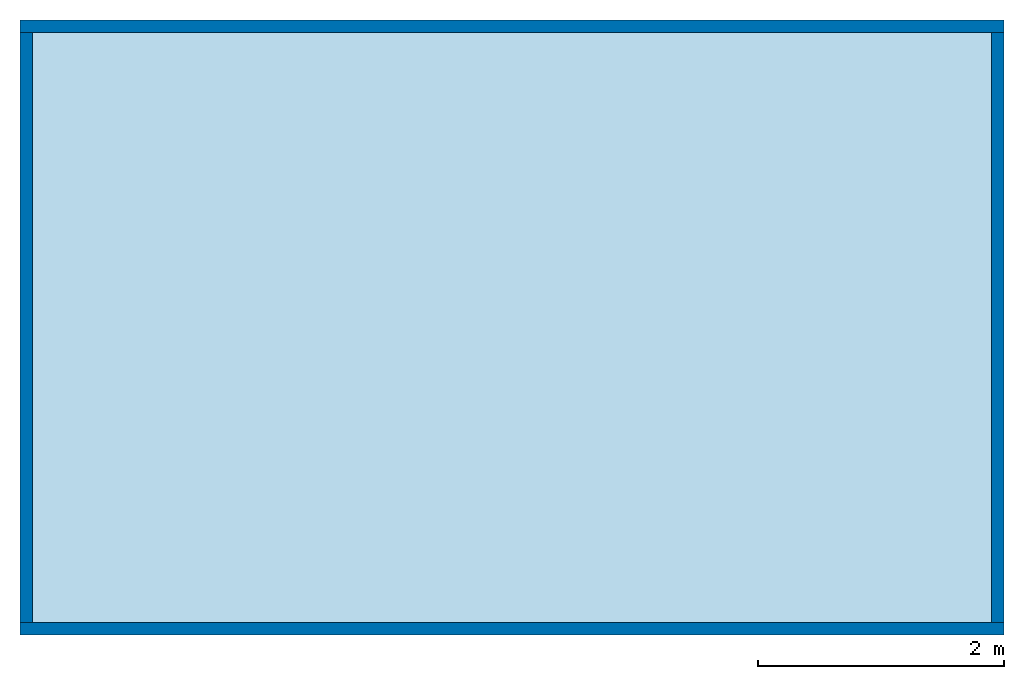
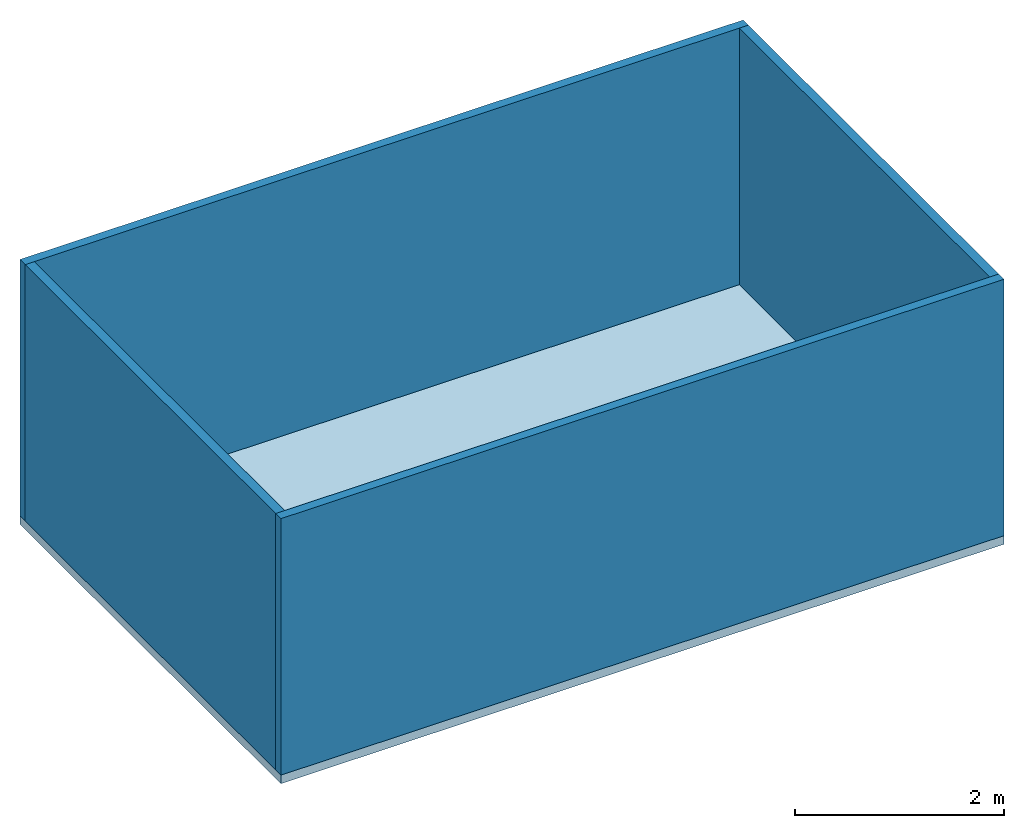
# One storey: 4 walls, 1 slab.
"""IFC4 building model written with IfcOpenShell, lengths in metres."""

from ifc_helpers import new_model, entity, si_unit, converted_unit, frame, origin_with_axes, origin_2d_with_axis, place, context, subcontext, project, spatial, line, indexed_curve, outline, extrude, material, layer, layer_set, layer_usage, type_object, element, save


model = new_model("IFC4")

# Units and contexts
model_context = context("Model", 3, precision=1e-05, world=origin_with_axes())
plan_context = context("Plan", 2, precision=1e-05, world=origin_2d_with_axis())
body_context = subcontext(model_context, "Body", "Model", "MODEL_VIEW")
ifc_project = project(units=[converted_unit("PLANEANGLEUNIT", "degree", entity("IfcReal", 0.0174532925199433), si_unit("PLANEANGLEUNIT", "RADIAN"), dimensions=[0, 0, 0, 0, 0, 0, 0]), si_unit("AREAUNIT", "SQUARE_METRE"), si_unit("VOLUMEUNIT", "CUBIC_METRE"), si_unit("LENGTHUNIT", "METRE")], contexts=[model_context, plan_context])

# Site, building, storey
site_placement = place(None, origin_with_axes())
site = spatial("IfcSite", under=ifc_project, at=site_placement)
building_placement = place(site_placement, origin_with_axes())
building = spatial("IfcBuilding", under=site, at=building_placement, Name="Building")
storey_placement = place(building_placement, origin_with_axes())
storey = spatial("IfcBuildingStorey", under=building, at=storey_placement, Name="Storey")

# Slab
ifc_material = material()
ifc_layer_1 = layer(ifc_material, 0.1)
ifc_layer_set_1 = layer_set([ifc_layer_1])
ifc_layer_usage_1 = layer_usage(ifc_layer_set_1, "AXIS3", "POSITIVE", 0.0)
slab_type = type_object("IfcSlabType", Name="slab", PredefinedType="FLOOR", material=ifc_layer_set_1)
slab_placement = place(storey_placement, frame((0.0, 0.0, -0.100000001490116), z_axis=(0.0, 0.0, 1.0), x_axis=(1.0, 0.0, 0.0)))
element("IfcSlab", 1, at=slab_placement, inside=storey, type_object=slab_type, material=ifc_layer_usage_1, Name="Slab", context=body_context, shape_type="SweptSolid", body=[
    extrude(outline(indexed_curve([(0.0, 0.0), (8.0, 0.0), (8.0, 5.0), (0.0, 5.0)], segments=[line(3, 2), line(2, 1), line(1, 4), line(4, 3)], self_intersect=False)), None, (0.0, 0.0, 1.0), 0.1),
])

# Walls
ifc_layer_2 = layer(ifc_material, 0.1)
ifc_layer_set_2 = layer_set([ifc_layer_2])
ifc_layer_usage_2 = layer_usage(ifc_layer_set_2, "AXIS2", "POSITIVE", 0.0)
wall_type = type_object("IfcWallType", Name="wall", PredefinedType="SOLIDWALL", material=ifc_layer_set_2)
wall_1_placement = place(storey_placement, origin_with_axes())
element("IfcWall", 2, at=wall_1_placement, inside=storey, type_object=wall_type, material=ifc_layer_usage_2, Name="Wall", context=body_context, shape_type="SweptSolid", body=[
    extrude(outline(indexed_curve([(0.0, 0.0), (0.0, 0.1), (8.0, 0.1), (8.0, 0.0), (0.0, 0.0)], self_intersect=False)), origin_with_axes(), (0.0, 0.0, 1.0), 3.0),
])
ifc_layer_usage_3 = layer_usage(ifc_layer_set_2, "AXIS2", "POSITIVE", 0.0)
wall_2_placement = place(storey_placement, frame((0.0, 4.90000009536743, 0.0), z_axis=(0.0, 0.0, 1.0), x_axis=(1.0, 0.0, 0.0)))
element("IfcWall", 3, at=wall_2_placement, inside=storey, type_object=wall_type, material=ifc_layer_usage_3, Name="Wall", context=body_context, shape_type="SweptSolid", body=[
    extrude(outline(indexed_curve([(0.0, 0.0), (0.0, 0.1), (8.0, 0.1), (8.0, 0.0), (0.0, 0.0)], self_intersect=False)), origin_with_axes(), (0.0, 0.0, 1.0), 3.0),
])
ifc_layer_usage_4 = layer_usage(ifc_layer_set_2, "AXIS2", "POSITIVE", 0.0)
wall_3_placement = place(storey_placement, frame((8.0, 0.0999999046325684, 0.0), z_axis=(0.0, 0.0, 1.0), x_axis=(7.54979012640431e-08, 0.999999999999997, 0.0)))
element("IfcWall", 4, at=wall_3_placement, inside=storey, type_object=wall_type, material=ifc_layer_usage_4, Name="Wall", context=body_context, shape_type="SweptSolid", body=[
    extrude(outline(indexed_curve([(0.0, 0.0), (0.0, 0.1), (4.79999830722788, 0.1), (4.79999830722788, 0.0), (0.0, 0.0)], self_intersect=False)), origin_with_axes(), (0.0, 0.0, 1.0), 3.0),
])
ifc_layer_usage_5 = layer_usage(ifc_layer_set_2, "AXIS2", "POSITIVE", 0.0)
wall_4_placement = place(storey_placement, frame((0.0999999046325684, 0.0999999046325684, 0.0), z_axis=(0.0, 0.0, 1.0), x_axis=(3.13916473260163e-07, 0.999999999999951, 0.0)))
element("IfcWall", 5, at=wall_4_placement, inside=storey, type_object=wall_type, material=ifc_layer_usage_5, Name="Wall", context=body_context, shape_type="SweptSolid", body=[
    extrude(outline(indexed_curve([(0.0, 0.0), (0.0, 0.1), (4.79999830722788, 0.1), (4.79999830722788, 0.0), (0.0, 0.0)], self_intersect=False)), origin_with_axes(), (0.0, 0.0, 1.0), 3.0),
])

save(model, "model.ifc")
